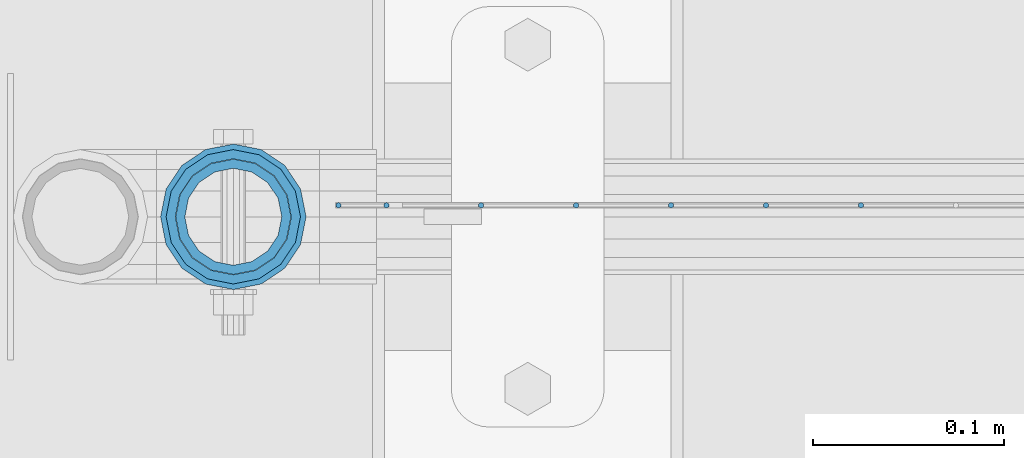
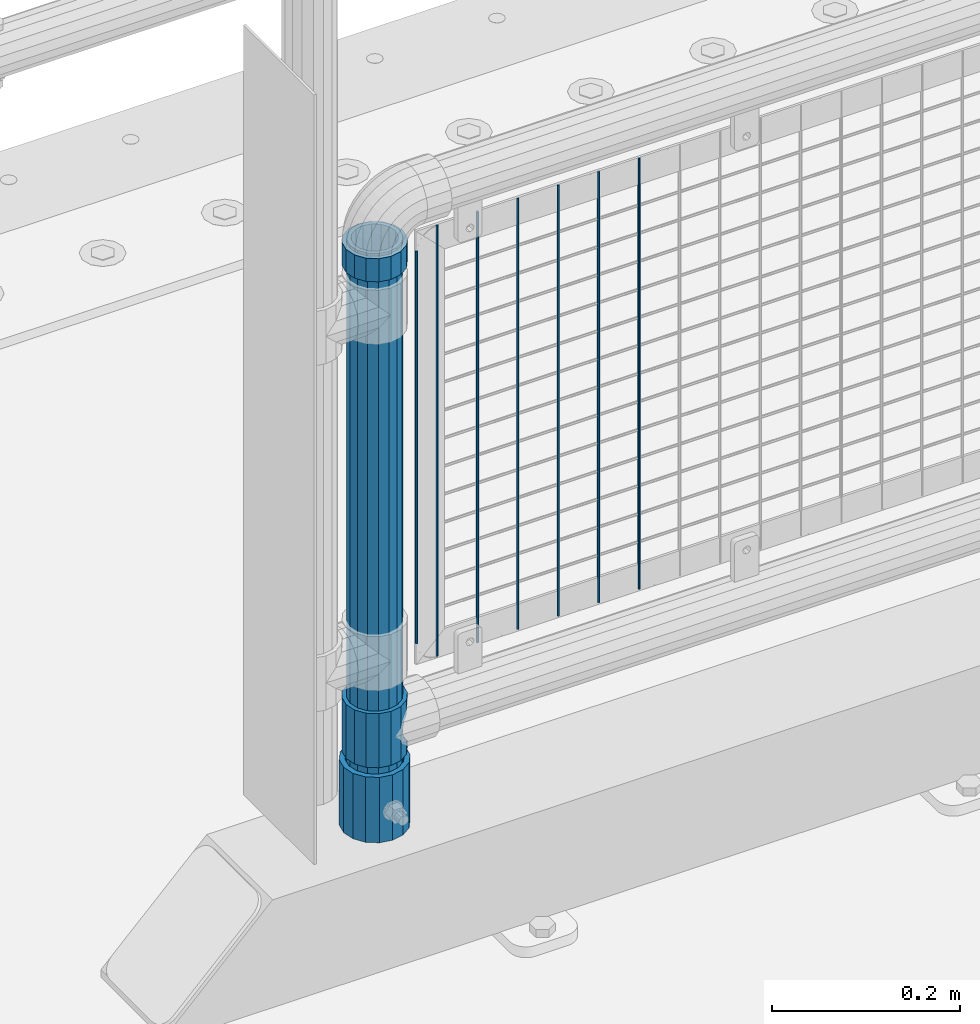
# One storey, part 68 of 247: 11 columns.
"""IFC2X3 building model written with IfcOpenShell, lengths in millimetres."""

from ifc_helpers import new_model, si_unit, frame, origin_with_axes, place, context, subcontext, project, spatial, faceted_brep, material, type_object, element, save


model = new_model("IFC2X3")

# Units and contexts
model_context = context("Model", 3, precision=1e-05, world=origin_with_axes())
body_context = subcontext(model_context, "Body", "Model", "MODEL_VIEW")
ifc_project = project(units=[si_unit("LENGTHUNIT", "METRE", prefix="MILLI"), si_unit("AREAUNIT", "SQUARE_METRE"), si_unit("VOLUMEUNIT", "CUBIC_METRE"), si_unit("MASSUNIT", "GRAM", prefix="KILO"), si_unit("TIMEUNIT", "SECOND"), si_unit("PLANEANGLEUNIT", "RADIAN"), si_unit("SOLIDANGLEUNIT", "STERADIAN"), si_unit("THERMODYNAMICTEMPERATUREUNIT", "DEGREE_CELSIUS"), si_unit("LUMINOUSINTENSITYUNIT", "LUMEN")], contexts=[model_context])

# Site, building, storey
site_placement = place(None, origin_with_axes())
site = spatial("IfcSite", under=ifc_project, at=site_placement, CompositionType="ELEMENT")
building_placement = place(site_placement, origin_with_axes())
building = spatial("IfcBuilding", under=site, at=building_placement, Name="Standard", CompositionType="ELEMENT")
storey_placement = place(building_placement, origin_with_axes())
storey = spatial("IfcBuildingStorey", under=building, at=storey_placement, Name="Undefined", CompositionType="ELEMENT", Elevation=0.0)

# Columns
ifc_material_1 = material()
column_type_1 = type_object("IfcColumnType", PredefinedType="NOTDEFINED")
column_1_placement = place(storey_placement, frame((620.999999804207, 7664.5, 168.019999999998), z_axis=(0.0, 1.0, 0.0), x_axis=(0.0, 0.0, 1.0)))
element("IfcColumn", 1, at=column_1_placement, inside=storey, type_object=column_type_1, material=ifc_material_1, context=body_context, shape_type="Brep", body=[
    faceted_brep([(0.0, -31.75, 0.0), (0.0, -29.3331751572332, 12.1501989775916), (85.0, -29.3331751572332, 12.1501989775916), (85.0, -31.75, 0.0), (0.0, -22.4506403026735, 22.4506403026726), (85.0, -22.4506403026735, 22.4506403026726), (0.0, -12.1501989775916, 29.3331751572332), (85.0, -12.1501989775916, 29.3331751572332), (0.0, 0.0, 31.75), (85.0, 0.0, 31.75), (0.0, 12.1501989775916, 29.3331751572332), (85.0, 12.1501989775916, 29.3331751572332), (0.0, 22.4506403026735, 22.4506403026726), (85.0, 22.4506403026735, 22.4506403026726), (0.0, 29.3331751572332, 12.1501989775916), (85.0, 29.3331751572332, 12.1501989775916), (0.0, 31.75, 0.0), (85.0, 31.75, 0.0), (0.0, 29.3331751572332, -12.1501989775916), (85.0, 29.3331751572332, -12.1501989775916), (0.0, 22.4506403026735, -22.4506403026726), (85.0, 22.4506403026735, -22.4506403026726), (0.0, 12.1501989775916, -29.3331751572332), (85.0, 12.1501989775916, -29.3331751572332), (0.0, 0.0, -31.75), (85.0, 0.0, -31.75), (0.0, -12.1501989775916, -29.3331751572332), (85.0, -12.1501989775916, -29.3331751572332), (0.0, -22.4506403026735, -22.4506403026726), (85.0, -22.4506403026735, -22.4506403026726), (0.0, -29.3331751572332, -12.1501989775916), (85.0, -29.3331751572332, -12.1501989775916), (0.0, -38.0499999999993, 0.0), (0.0, -35.1536162120537, -14.5611046014919), (85.0, -35.1536162120537, -14.5611046014919), (85.0, -38.0499999999993, 0.0), (0.0, -26.9054130241475, -26.9054130241484), (85.0, -26.9054130241475, -26.9054130241484), (0.0, -14.561104601491, -35.1536162120547), (85.0, -14.561104601491, -35.1536162120547), (0.0, 0.0, -38.0500000000002), (85.0, 0.0, -38.0500000000002), (0.0, 14.561104601491, -35.1536162120547), (85.0, 14.561104601491, -35.1536162120547), (0.0, 26.9054130241475, -26.9054130241484), (85.0, 26.9054130241475, -26.9054130241484), (0.0, 35.1536162120537, -14.5611046014919), (85.0, 35.1536162120537, -14.5611046014919), (0.0, 38.0499999999993, 0.0), (85.0, 38.0499999999993, 0.0), (0.0, 35.1536162120537, 14.5611046014919), (85.0, 35.1536162120537, 14.5611046014919), (0.0, 26.9054130241475, 26.9054130241484), (85.0, 26.9054130241475, 26.9054130241484), (0.0, 14.561104601491, 35.1536162120547), (85.0, 14.561104601491, 35.1536162120547), (0.0, 0.0, 38.0500000000002), (85.0, 0.0, 38.0500000000002), (0.0, -14.561104601491, 35.1536162120547), (85.0, -14.561104601491, 35.1536162120547), (0.0, -26.9054130241475, 26.9054130241484), (85.0, -26.9054130241475, 26.9054130241484), (0.0, -35.1536162120537, 14.5611046014919), (85.0, -35.1536162120537, 14.5611046014919)], [[[0, 1, 2, 3]], [[1, 4, 5, 2]], [[4, 6, 7, 5]], [[6, 8, 9, 7]], [[8, 10, 11, 9]], [[10, 12, 13, 11]], [[12, 14, 15, 13]], [[14, 16, 17, 15]], [[16, 18, 19, 17]], [[18, 20, 21, 19]], [[20, 22, 23, 21]], [[22, 24, 25, 23]], [[24, 26, 27, 25]], [[26, 28, 29, 27]], [[28, 30, 31, 29]], [[30, 0, 3, 31]], [[32, 33, 34, 35]], [[33, 36, 37, 34]], [[36, 38, 39, 37]], [[38, 40, 41, 39]], [[40, 42, 43, 41]], [[42, 44, 45, 43]], [[44, 46, 47, 45]], [[46, 48, 49, 47]], [[48, 50, 51, 49]], [[50, 52, 53, 51]], [[52, 54, 55, 53]], [[54, 56, 57, 55]], [[56, 58, 59, 57]], [[58, 60, 61, 59]], [[60, 62, 63, 61]], [[62, 32, 35, 63]], [[37, 39, 41, 43, 45, 47, 49, 51, 53, 55, 57, 59, 61, 63, 35, 34], [5, 7, 9, 11, 13, 15, 17, 19, 21, 23, 25, 27, 29, 31, 3, 2]], [[62, 60, 58, 56, 54, 52, 50, 48, 46, 44, 42, 40, 38, 36, 33, 32], [30, 28, 26, 24, 22, 20, 18, 16, 14, 12, 10, 8, 6, 4, 1, 0]]]),
])
ifc_material_2 = material(Name="Misc_Undefined")
column_type_2 = type_object("IfcColumnType", PredefinedType="NOTDEFINED")
column_2_placement = place(storey_placement, frame((621.0, 7664.5, 263.52), z_axis=(-1.0, 0.0, 0.0), x_axis=(0.0, 0.0, 1.0)))
element("IfcColumn", 2, at=column_2_placement, inside=storey, type_object=column_type_2, material=ifc_material_2, context=body_context, shape_type="Brep", body=[
    faceted_brep([(56.6106908090114, 21.4606908090118, -21.4606908090118), (56.6106908090114, 21.4606908090118, -27.1226768591096), (61.9623795176755, 13.4513226476329, -32.4743655677721), (63.1897438117172, 11.6144421722802, -32.839743811719), (63.1897438117172, 11.6144421722802, -28.0397438117179), (46.7644421722801, 28.0397438117179, -11.6144421722802), (46.7644421722801, 28.0397438117179, -20.088203122983), (51.5310424080055, 24.8548033587067, -24.8548033587067), (35.1499999999996, 30.35, 0.0), (35.1499999999996, 30.3500000000004, -16.6306603983649), (23.5355578277192, 28.0397438117179, -11.6144421722802), (23.5355578277192, 28.0397438117179, -20.088203122983), (13.6893091909879, 21.4606908090118, -21.4606908090118), (13.6893091909879, 21.4606908090118, -27.1226768591096), (18.768957591997, 24.8548033587067, -24.8548033587067), (7.11025618828211, 11.6144421722802, -28.0397438117179), (7.11025618828211, 11.6144421722802, -32.839743811719), (8.33762048232387, 13.4513226476329, -32.4743655677721), (4.79999999999961, 0.0, -30.3500000000004), (4.79999999999961, 0.0, -35.1499999999996), (7.11025618828211, -11.6144421722802, -28.0397438117179), (7.11025618828211, -11.6144421722802, -32.839743811719), (13.6893091909879, -21.4606908090118, -21.4606908090118), (13.6893091909879, -21.4606908090118, -27.1226768591077), (8.33762048232325, -13.4513226476329, -32.4743655677721), (23.5355578277191, -28.0397438117179, -11.6144421722802), (23.5355578277191, -28.0397438117179, -20.0882031229885), (18.768957591997, -24.8548033587067, -24.8548033587067), (35.1499999999996, -30.35, 0.0), (35.1499999999996, -30.3500000000004, -16.6306603983739), (46.7644421722801, -28.0397438117179, -11.6144421722802), (46.7644421722801, -28.0397438117179, -20.0882031229885), (56.6106908090114, -21.4606908090118, -21.4606908090118), (56.6106908090114, -21.4606908090118, -27.1226768591077), (51.5310424080038, -24.8548033587067, -24.8548033587067), (63.1897438117172, -11.6144421722802, -28.0397438117179), (63.1897438117172, -11.6144421722802, -32.839743811719), (61.9623795176754, -13.4513226476329, -32.4743655677721), (65.4999999999997, 0.0, -30.3500000000004), (65.4999999999997, 0.0, -35.1499999999996), (70.2999999999993, -11.6144421722802, -28.0397438117179), (70.2999999999993, 0.0, -30.3500000000004), (70.2999999999993, -21.4606908090118, -21.4606908090118), (70.2999999999993, -28.0397438117179, -11.6144421722802), (70.2999999999993, -30.3500000000004, 0.0), (0.0, -28.0397438117179, -11.6144421722802), (0.0, -30.3500000000004, 0.0), (0.0, -21.4606908090118, -21.4606908090118), (0.0, -11.6144421722802, -28.0397438117179), (0.0, 0.0, -30.3500000000004), (0.0, 11.6144421722802, -28.0397438117179), (0.0, 21.4606908090118, -21.4606908090118), (0.0, 28.0397438117179, -11.6144421722802), (0.0, 30.3500000000004, 0.0), (0.0, -24.8548033587067, -24.8548033587067), (0.0, -13.4513226476329, -32.4743655677721), (0.0, 0.0, -35.1499999999996), (0.0, 13.4513226476329, -32.4743655677721), (0.0, 24.8548033587067, -24.8548033587067), (0.0, -32.4743655677721, 13.4513226476338), (0.0, -35.1499999999996, 0.0), (70.2999999999993, -35.1499999999996, 0.0), (70.2999999999993, -32.4743655677721, 13.4513226476338), (0.0, -24.8548033587067, 24.8548033587067), (70.2999999999993, -24.8548033587067, 24.8548033587067), (0.0, -13.4513226476329, 32.4743655677721), (70.2999999999993, -13.4513226476329, 32.4743655677721), (0.0, 0.0, 35.1499999999996), (70.2999999999993, 0.0, 35.1499999999996), (0.0, 13.4513226476329, 32.4743655677721), (70.2999999999993, 13.4513226476329, 32.4743655677721), (0.0, 24.8548033587067, 24.8548033587067), (70.2999999999993, 24.8548033587067, 24.8548033587067), (0.0, 32.4743655677721, 13.4513226476338), (70.2999999999993, 32.4743655677721, 13.4513226476338), (0.0, 35.1499999999996, 0.0), (70.2999999999993, 35.1499999999996, 0.0), (0.0, 32.4743655677721, -13.4513226476338), (70.2999999999993, 32.4743655677721, -13.4513226476338), (70.2999999999993, 24.8548033587067, -24.8548033587067), (70.2999999999993, 13.4513226476329, -32.4743655677721), (70.2999999999993, 0.0, -35.1499999999996), (70.2999999999993, -13.4513226476329, -32.4743655677721), (70.2999999999993, -24.8548033587067, -24.8548033587067), (70.2999999999993, -32.4743655677721, -13.4513226476338), (0.0, -32.4743655677721, -13.4513226476338), (0.0, 28.0397438117179, 11.6144421722802), (0.0, 21.4606908090118, 21.4606908090118), (0.0, 11.6144421722802, 28.0397438117179), (0.0, 0.0, 30.3500000000004), (0.0, -11.6144421722802, 28.0397438117179), (0.0, -21.4606908090118, 21.4606908090118), (0.0, -28.0397438117179, 11.6144421722802), (70.2999999999993, 28.0397438117179, 11.6144421722802), (70.2999999999993, 21.4606908090118, 21.4606908090118), (70.2999999999993, 11.6144421722802, 28.0397438117179), (70.2999999999993, 0.0, 30.3500000000004), (70.2999999999993, -11.6144421722802, 28.0397438117179), (70.2999999999993, -21.4606908090118, 21.4606908090118), (70.2999999999993, -28.0397438117179, 11.6144421722802), (70.2999999999993, 30.3500000000004, 0.0), (70.2999999999993, 28.0397438117179, -11.6144421722802), (70.2999999999993, 21.4606908090118, -21.4606908090118), (70.2999999999993, 11.6144421722802, -28.0397438117179)], [[[0, 1, 2, 3, 4]], [[5, 6, 7, 1, 0]], [[8, 9, 6, 5]], [[10, 11, 9, 8]], [[12, 13, 14, 11, 10]], [[15, 16, 17, 13, 12]], [[18, 19, 16, 15]], [[20, 21, 19, 18]], [[22, 23, 24, 21, 20]], [[25, 26, 27, 23, 22]], [[28, 29, 26, 25]], [[30, 31, 29, 28]], [[32, 33, 34, 31, 30]], [[35, 36, 37, 33, 32]], [[38, 39, 36, 35]], [[4, 3, 39, 38]], [[40, 41, 38, 35]], [[42, 40, 35, 32]], [[43, 42, 32, 30]], [[44, 43, 30, 28]], [[45, 46, 28, 25]], [[47, 45, 25, 22]], [[48, 47, 22, 20]], [[49, 48, 20, 18]], [[50, 49, 18, 15]], [[51, 50, 15, 12]], [[52, 51, 12, 10]], [[53, 52, 10, 8]], [[54, 55, 24, 23, 27]], [[55, 56, 19, 21, 24]], [[19, 56, 57, 17, 16]], [[17, 57, 58, 14, 13]], [[59, 60, 61, 62]], [[63, 59, 62, 64]], [[65, 63, 64, 66]], [[67, 65, 66, 68]], [[69, 67, 68, 70]], [[71, 69, 70, 72]], [[73, 71, 72, 74]], [[75, 73, 74, 76]], [[77, 75, 76, 78]], [[14, 58, 77, 78, 79, 7, 6, 9, 11]], [[79, 80, 2, 1, 7]], [[80, 81, 39, 3, 2]], [[37, 82, 83, 34, 33]], [[39, 81, 82, 37, 36]], [[34, 83, 84, 85, 54, 27, 26, 29, 31]], [[60, 85, 84, 61]], [[59, 63, 65, 67, 69, 71, 73, 75, 77, 58, 57, 56, 55, 54, 85, 60], [45, 47, 48, 49, 50, 51, 52, 53, 86, 87, 88, 89, 90, 91, 92, 46]], [[87, 86, 93, 94]], [[88, 87, 94, 95]], [[89, 88, 95, 96]], [[90, 89, 96, 97]], [[91, 90, 97, 98]], [[92, 91, 98, 99]], [[28, 46, 92, 99, 44]], [[83, 82, 81, 80, 79, 78, 76, 74, 72, 70, 68, 66, 64, 62, 61, 84], [98, 97, 96, 95, 94, 93, 100, 101, 102, 103, 41, 40, 42, 43, 44, 99]], [[86, 53, 8, 100, 93]], [[101, 100, 8, 5]], [[102, 101, 5, 0]], [[103, 102, 0, 4]], [[41, 103, 4, 38]]]),
])
column_3_placement = place(storey_placement, frame((621.0, 7664.5, 894.849999999999), z_axis=(-1.0, 0.0, 0.0), x_axis=(0.0, 0.0, 1.0)))
element("IfcColumn", 3, at=column_3_placement, inside=storey, type_object=column_type_2, material=ifc_material_2, context=body_context, shape_type="Brep", body=[
    faceted_brep([(0.0, -30.3500000000004, 0.0), (0.0, -28.0397438117179, 11.6144421722802), (30.0, -28.0397438117179, 11.6144421722805), (30.0, -30.3500000000004, 0.0), (0.0, -21.4606908090118, 21.4606908090118), (30.0, -21.4606908090118, 21.4606908090117), (0.0, -11.6144421722802, 28.0397438117179), (30.0, -11.6144421722802, 28.0397438117175), (0.0, 0.0, 30.3500000000004), (30.0, 0.0, 30.35), (0.0, 11.6144421722802, 28.0397438117179), (30.0, 11.6144421722802, 28.0397438117175), (0.0, 21.4606908090118, 21.4606908090118), (30.0, 21.4606908090118, 21.4606908090117), (0.0, 28.0397438117179, 11.6144421722802), (30.0, 28.0397438117179, 11.6144421722805), (0.0, 30.3500000000004, 0.0), (30.0, 30.3500000000004, 0.0), (0.0, 28.0397438117179, -11.6144421722802), (30.0, 28.0397438117179, -11.6144421722805), (0.0, 21.4606908090118, -21.4606908090118), (30.0, 21.4606908090118, -21.4606908090117), (0.0, 11.6144421722802, -28.0397438117179), (30.0, 11.6144421722802, -28.0397438117175), (0.0, 0.0, -30.3500000000004), (30.0, 0.0, -30.35), (0.0, -11.6144421722802, -28.0397438117179), (30.0, -11.6144421722802, -28.0397438117175), (0.0, -21.4606908090118, -21.4606908090118), (30.0, -21.4606908090118, -21.4606908090117), (0.0, -28.0397438117179, -11.6144421722802), (30.0, -28.0397438117179, -11.6144421722805), (0.0, -35.1499999999996, 0.0), (0.0, -32.4743655677721, -13.4513226476338), (30.0, -32.4743655677721, -13.4513226476329), (30.0, -35.1499999999996, 0.0), (0.0, -24.8548033587067, -24.8548033587067), (30.0, -24.8548033587067, -24.8548033587072), (0.0, -13.4513226476329, -32.4743655677721), (30.0, -13.4513226476329, -32.4743655677717), (0.0, 0.0, -35.1499999999996), (30.0, 0.0, -35.15), (0.0, 13.4513226476329, -32.4743655677721), (30.0, 13.4513226476329, -32.4743655677717), (0.0, 24.8548033587067, -24.8548033587067), (30.0, 24.8548033587067, -24.8548033587072), (0.0, 32.4743655677721, -13.4513226476338), (30.0, 32.4743655677721, -13.4513226476329), (0.0, 35.1499999999996, 0.0), (30.0, 35.1499999999996, 0.0), (0.0, 32.4743655677721, 13.4513226476338), (30.0, 32.4743655677721, 13.4513226476329), (0.0, 24.8548033587067, 24.8548033587067), (30.0, 24.8548033587067, 24.8548033587072), (0.0, 13.4513226476329, 32.4743655677721), (30.0, 13.4513226476329, 32.4743655677717), (0.0, 0.0, 35.1499999999996), (30.0, 0.0, 35.15), (0.0, -13.4513226476329, 32.4743655677721), (30.0, -13.4513226476329, 32.4743655677717), (0.0, -24.8548033587067, 24.8548033587067), (30.0, -24.8548033587067, 24.8548033587072), (0.0, -32.4743655677721, 13.4513226476338), (30.0, -32.4743655677721, 13.4513226476329)], [[[0, 1, 2, 3]], [[1, 4, 5, 2]], [[4, 6, 7, 5]], [[6, 8, 9, 7]], [[8, 10, 11, 9]], [[10, 12, 13, 11]], [[12, 14, 15, 13]], [[14, 16, 17, 15]], [[16, 18, 19, 17]], [[18, 20, 21, 19]], [[20, 22, 23, 21]], [[22, 24, 25, 23]], [[24, 26, 27, 25]], [[26, 28, 29, 27]], [[28, 30, 31, 29]], [[30, 0, 3, 31]], [[32, 33, 34, 35]], [[33, 36, 37, 34]], [[36, 38, 39, 37]], [[38, 40, 41, 39]], [[40, 42, 43, 41]], [[42, 44, 45, 43]], [[44, 46, 47, 45]], [[46, 48, 49, 47]], [[48, 50, 51, 49]], [[50, 52, 53, 51]], [[52, 54, 55, 53]], [[54, 56, 57, 55]], [[56, 58, 59, 57]], [[58, 60, 61, 59]], [[60, 62, 63, 61]], [[62, 32, 35, 63]], [[37, 39, 41, 43, 45, 47, 49, 51, 53, 55, 57, 59, 61, 63, 35, 34], [5, 7, 9, 11, 13, 15, 17, 19, 21, 23, 25, 27, 29, 31, 3, 2]], [[62, 60, 58, 56, 54, 52, 50, 48, 46, 44, 42, 40, 38, 36, 33, 32], [30, 28, 26, 24, 22, 20, 18, 16, 14, 12, 10, 8, 6, 4, 1, 0]]]),
])
column_type_3 = type_object("IfcColumnType", PredefinedType="NOTDEFINED")
column_4_placement = place(storey_placement, frame((620.999999804207, 7664.5, 168.019999999998), z_axis=(-1.0, 0.0, 0.0), x_axis=(0.0, 0.0, 1.0)))
element("IfcColumn", 4, at=column_4_placement, inside=storey, type_object=column_type_3, material=ifc_material_1, context=body_context, shape_type="Brep", body=[
    faceted_brep([(0.0, -25.3500000000004, 0.0), (0.0, -23.4203461491616, 9.70102501045585), (760.0, -23.4203461491616, 9.70102501045585), (760.0, -25.3500000000004, 0.0), (0.0, -17.9251569030794, 17.9251569030785), (760.0, -17.9251569030794, 17.9251569030785), (0.0, -9.70102501045494, 23.4203461491616), (760.0, -9.70102501045494, 23.4203461491616), (0.0, 0.0, 25.3500000000004), (760.0, 0.0, 25.3500000000004), (0.0, 9.70102501045494, 23.4203461491616), (760.0, 9.70102501045494, 23.4203461491616), (0.0, 17.9251569030794, 17.9251569030785), (760.0, 17.9251569030794, 17.9251569030785), (0.0, 23.4203461491616, 9.70102501045585), (760.0, 23.4203461491616, 9.70102501045585), (0.0, 25.3500000000004, 0.0), (760.0, 25.3500000000004, 0.0), (0.0, 23.4203461491616, -9.70102501045585), (760.0, 23.4203461491616, -9.70102501045585), (0.0, 17.9251569030794, -17.9251569030785), (760.0, 17.9251569030794, -17.9251569030785), (0.0, 9.70102501045494, -23.4203461491616), (760.0, 9.70102501045494, -23.4203461491616), (0.0, 0.0, -25.3500000000004), (760.0, 0.0, -25.3500000000004), (0.0, -9.70102501045494, -23.4203461491616), (760.0, -9.70102501045494, -23.4203461491616), (0.0, -17.9251569030794, -17.9251569030785), (760.0, -17.9251569030794, -17.9251569030785), (0.0, -23.4203461491616, -9.70102501045585), (760.0, -23.4203461491616, -9.70102501045585), (0.0, -30.1499999999996, 0.0), (0.0, -27.8549679052148, -11.5379054858076), (760.0, -27.8549679052148, -11.5379054858076), (760.0, -30.1499999999996, 0.0), (0.0, -21.3192694527743, -21.3192694527752), (760.0, -21.3192694527743, -21.3192694527752), (0.0, -11.5379054858076, -27.8549679052157), (760.0, -11.5379054858076, -27.8549679052157), (0.0, 0.0, -30.1499999999996), (760.0, 0.0, -30.1499999999996), (0.0, 11.5379054858076, -27.8549679052157), (760.0, 11.5379054858076, -27.8549679052157), (0.0, 21.3192694527743, -21.3192694527752), (760.0, 21.3192694527743, -21.3192694527752), (0.0, 27.8549679052157, -11.5379054858076), (760.0, 27.8549679052157, -11.5379054858076), (0.0, 30.1499999999996, 0.0), (760.0, 30.1499999999996, 0.0), (0.0, 27.8549679052157, 11.5379054858076), (760.0, 27.8549679052157, 11.5379054858076), (0.0, 21.3192694527743, 21.3192694527752), (760.0, 21.3192694527743, 21.3192694527752), (0.0, 11.5379054858076, 27.8549679052157), (760.0, 11.5379054858076, 27.8549679052157), (0.0, 0.0, 30.1499999999996), (760.0, 0.0, 30.1499999999996), (0.0, -11.5379054858076, 27.8549679052157), (760.0, -11.5379054858076, 27.8549679052157), (0.0, -21.3192694527743, 21.3192694527752), (760.0, -21.3192694527743, 21.3192694527752), (0.0, -27.8549679052157, 11.5379054858076), (760.0, -27.8549679052157, 11.5379054858076)], [[[0, 1, 2, 3]], [[1, 4, 5, 2]], [[4, 6, 7, 5]], [[6, 8, 9, 7]], [[8, 10, 11, 9]], [[10, 12, 13, 11]], [[12, 14, 15, 13]], [[14, 16, 17, 15]], [[16, 18, 19, 17]], [[18, 20, 21, 19]], [[20, 22, 23, 21]], [[22, 24, 25, 23]], [[24, 26, 27, 25]], [[26, 28, 29, 27]], [[28, 30, 31, 29]], [[30, 0, 3, 31]], [[32, 33, 34, 35]], [[33, 36, 37, 34]], [[36, 38, 39, 37]], [[38, 40, 41, 39]], [[40, 42, 43, 41]], [[42, 44, 45, 43]], [[44, 46, 47, 45]], [[46, 48, 49, 47]], [[48, 50, 51, 49]], [[50, 52, 53, 51]], [[52, 54, 55, 53]], [[54, 56, 57, 55]], [[56, 58, 59, 57]], [[58, 60, 61, 59]], [[60, 62, 63, 61]], [[62, 32, 35, 63]], [[37, 39, 41, 43, 45, 47, 49, 51, 53, 55, 57, 59, 61, 63, 35, 34], [5, 7, 9, 11, 13, 15, 17, 19, 21, 23, 25, 27, 29, 31, 3, 2]], [[62, 60, 58, 56, 54, 52, 50, 48, 46, 44, 42, 40, 38, 36, 33, 32], [30, 28, 26, 24, 22, 20, 18, 16, 14, 12, 10, 8, 6, 4, 1, 0]]]),
])
column_type_4 = type_object("IfcColumnType", Name="D3", PredefinedType="NOTDEFINED")
for number, where, z_axis, x_axis in (
    (5, (949.275, 7670.5, 353.02), (-1.0, 0.0, 0.0), (0.0, 0.0, 1.0)),
    (6, (899.62, 7670.5, 353.02), (-1.0, 0.0, 0.0), (0.0, 0.0, 1.0)),
    (7, (849.965, 7670.5, 353.02), (-1.0, 0.0, 0.0), (0.0, 0.0, 1.0)),
    (8, (800.310344827586, 7670.5, 353.02), (-0.999999999851374, 0.0, 1.72409999974503e-05), (1.72409999974989e-05, 0.0, 0.999999999851374)),
    (9, (750.655172413793, 7670.5, 353.02), (-0.999999999962839, 0.0, 8.62099999968473e-06), (8.62099999949798e-06, 0.0, 0.999999999962839)),
):
    element("IfcColumn", number, at=place(storey_placement, frame(where, z_axis=z_axis, x_axis=x_axis)), inside=storey, type_object=column_type_4, material=ifc_material_2, ObjectType="D3", context=body_context, shape_type="Brep", body=[
        faceted_brep([(1.81898940354586e-12, -1.5, -5.6843418860808e-14), (0.0, -0.75, -1.29903810567703), (560.0, -0.75, -1.29903810567703), (560.0, -1.5, 0.0), (0.0, 0.75, -1.29903810567703), (560.0, 0.75, -1.29903810567703), (1.81898940354586e-12, 1.5, -5.6843418860808e-14), (560.0, 1.5, 0.0), (0.0, 0.75, 1.29903810567703), (560.0, 0.75, 1.29903810567703), (0.0, -0.75, 1.29903810567703), (560.0, -0.75, 1.29903810567703)], [[[0, 1, 2, 3]], [[1, 4, 5, 2]], [[4, 6, 7, 5]], [[6, 8, 9, 7]], [[8, 10, 11, 9]], [[10, 0, 3, 11]], [[5, 7, 9, 11, 3, 2]], [[10, 8, 6, 4, 1, 0]]]),
    ])
column_5_placement = place(storey_placement, frame((676.0, 7670.5, 378.02), z_axis=(-1.0, 0.0, 0.0), x_axis=(0.0, 0.0, 1.0)))
element("IfcColumn", 10, at=column_5_placement, inside=storey, type_object=column_type_4, material=ifc_material_2, ObjectType="D3", context=body_context, shape_type="Brep", body=[
    faceted_brep([(1.81898940354586e-12, -1.5, -5.6843418860808e-14), (0.0, -0.75, -1.29903810567703), (510.0, -0.75, -1.29903810567703), (510.0, -1.5, 0.0), (0.0, 0.75, -1.29903810567703), (510.0, 0.75, -1.29903810567703), (1.81898940354586e-12, 1.5, -5.6843418860808e-14), (510.0, 1.5, 0.0), (0.0, 0.75, 1.29903810567703), (510.0, 0.75, 1.29903810567703), (0.0, -0.75, 1.29903810567703), (510.0, -0.75, 1.29903810567703)], [[[0, 1, 2, 3]], [[1, 4, 5, 2]], [[4, 6, 7, 5]], [[6, 8, 9, 7]], [[8, 10, 11, 9]], [[10, 0, 3, 11]], [[5, 7, 9, 11, 3, 2]], [[10, 8, 6, 4, 1, 0]]]),
])
column_6_placement = place(storey_placement, frame((701.0, 7670.5, 353.02), z_axis=(-1.0, 0.0, 0.0), x_axis=(0.0, 0.0, 1.0)))
element("IfcColumn", 11, at=column_6_placement, inside=storey, type_object=column_type_4, material=ifc_material_2, ObjectType="D3", context=body_context, shape_type="Brep", body=[
    faceted_brep([(1.81898940354586e-12, -1.5, -5.6843418860808e-14), (0.0, -0.75, -1.29903810567703), (560.0, -0.75, -1.29903810567703), (560.0, -1.5, 0.0), (0.0, 0.75, -1.29903810567703), (560.0, 0.75, -1.29903810567703), (1.81898940354586e-12, 1.5, -5.6843418860808e-14), (560.0, 1.5, 0.0), (0.0, 0.75, 1.29903810567703), (560.0, 0.75, 1.29903810567703), (0.0, -0.75, 1.29903810567703), (560.0, -0.75, 1.29903810567703)], [[[0, 1, 2, 3]], [[1, 4, 5, 2]], [[4, 6, 7, 5]], [[6, 8, 9, 7]], [[8, 10, 11, 9]], [[10, 0, 3, 11]], [[5, 7, 9, 11, 3, 2]], [[10, 8, 6, 4, 1, 0]]]),
])

save(model, "model.ifc")
